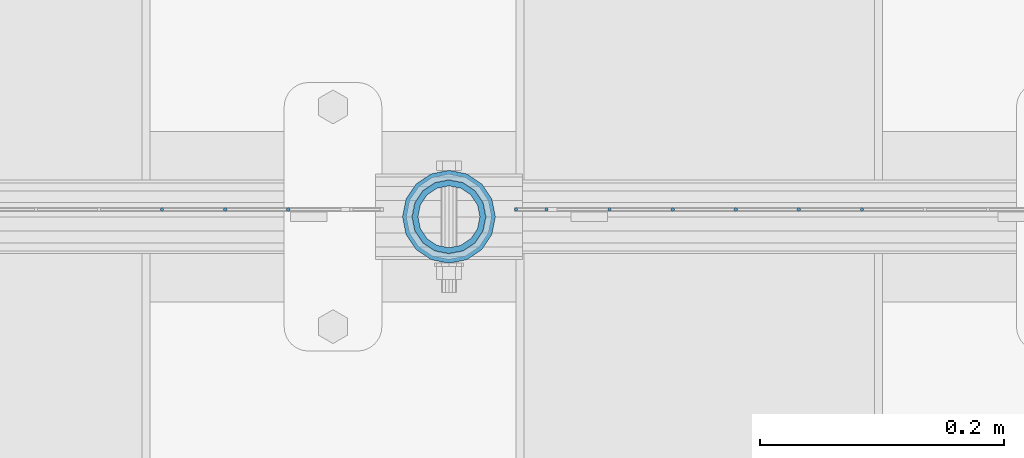
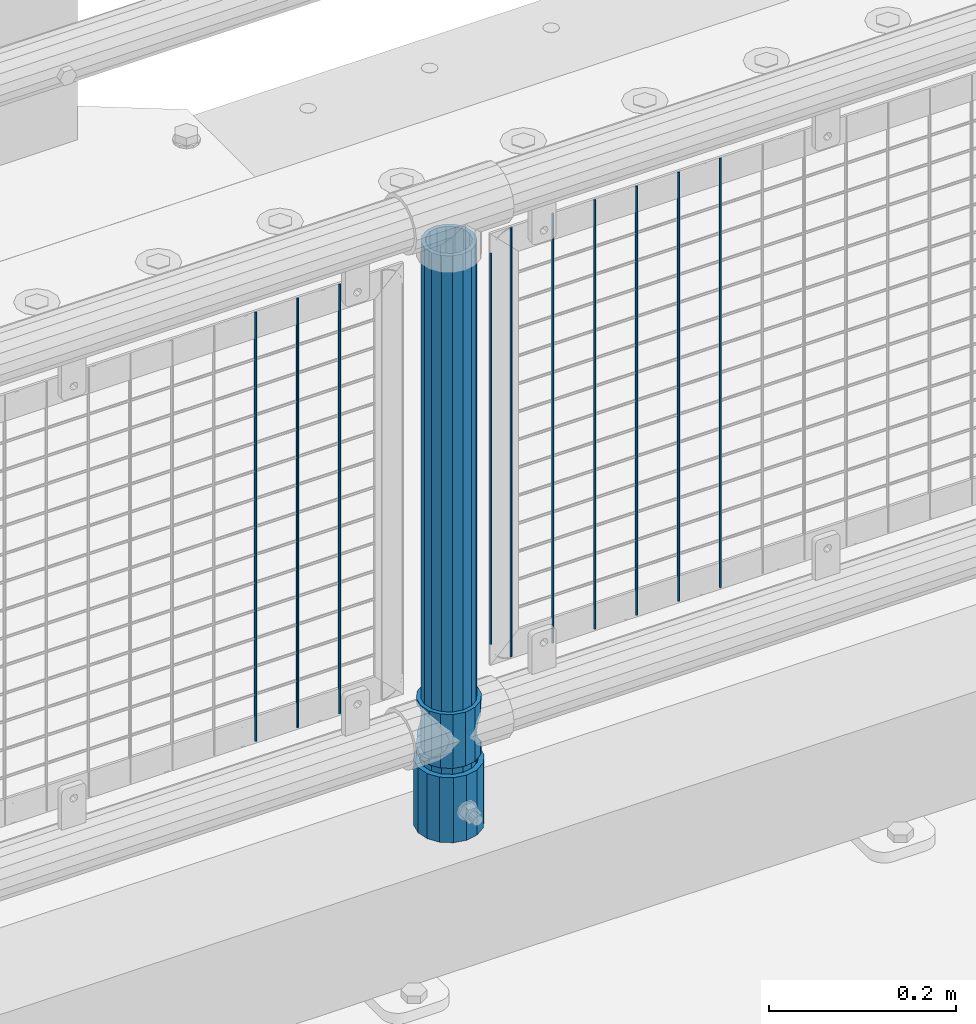
# One storey, part 74 of 219: 13 columns.
"""IFC2X3 building model written with IfcOpenShell, lengths in millimetres."""

from ifc_helpers import new_model, si_unit, frame, origin_with_axes, place, context, subcontext, project, spatial, faceted_brep, material, type_object, element, save


model = new_model("IFC2X3")

# Units and contexts
model_context = context("Model", 3, precision=1e-05, world=origin_with_axes())
body_context = subcontext(model_context, "Body", "Model", "MODEL_VIEW")
ifc_project = project(units=[si_unit("LENGTHUNIT", "METRE", prefix="MILLI"), si_unit("AREAUNIT", "SQUARE_METRE"), si_unit("VOLUMEUNIT", "CUBIC_METRE"), si_unit("MASSUNIT", "GRAM", prefix="KILO"), si_unit("TIMEUNIT", "SECOND"), si_unit("PLANEANGLEUNIT", "RADIAN"), si_unit("SOLIDANGLEUNIT", "STERADIAN"), si_unit("THERMODYNAMICTEMPERATUREUNIT", "DEGREE_CELSIUS"), si_unit("LUMINOUSINTENSITYUNIT", "LUMEN")], contexts=[model_context])

# Site, building, storey
site_placement = place(None, origin_with_axes())
site = spatial("IfcSite", under=ifc_project, at=site_placement, CompositionType="ELEMENT")
building_placement = place(site_placement, origin_with_axes())
building = spatial("IfcBuilding", under=site, at=building_placement, Name="Standard", CompositionType="ELEMENT")
storey_placement = place(building_placement, origin_with_axes())
storey = spatial("IfcBuildingStorey", under=building, at=storey_placement, Name="Undefined", CompositionType="ELEMENT", Elevation=0.0)

# Columns
ifc_material_1 = material(Name="Misc_Undefined")
column_type_1 = type_object("IfcColumnType", PredefinedType="NOTDEFINED")
column_1_placement = place(storey_placement, frame((5595.0, 31664.5, 263.02), z_axis=(-1.0, 0.0, 0.0), x_axis=(0.0, 0.0, 1.0)))
element("IfcColumn", 1, at=column_1_placement, inside=storey, type_object=column_type_1, material=ifc_material_1, context=body_context, shape_type="Brep", body=[
    faceted_brep([(56.6106908090114, 21.46069080901, -21.4606908090118), (56.6106908090114, 21.46069080901, -27.1226768591096), (61.9623795176703, 13.4513226476338, -32.4743655677721), (63.1897438117172, 11.614442172282, -32.8397438117172), (63.1897438117172, 11.614442172282, -28.0397438117179), (46.7644421722801, 28.0397438117179, -11.6144421722802), (46.7644421722801, 28.0397438117179, -20.0882031229849), (51.5310424080006, 24.8548033587067, -24.8548033587067), (35.1499999999996, 30.35, 0.0), (35.1499999999996, 30.3499999999985, -16.6306603983739), (23.5355578277192, 28.0397438117179, -11.6144421722802), (23.5355578277192, 28.0397438117179, -20.0882031229849), (13.6893091909879, 21.46069080901, -21.4606908090118), (13.6893091909879, 21.46069080901, -27.1226768591096), (18.7689575919987, 24.8548033587067, -24.8548033587067), (7.11025618828211, 11.614442172282, -28.0397438117179), (7.11025618828211, 11.614442172282, -32.8397438117172), (8.33762048232455, 13.4513226476338, -32.4743655677721), (4.79999999999961, 0.0, -30.3500000000004), (4.79999999999961, 0.0, -35.1499999999996), (7.11025618828211, -11.614442172282, -28.0397438117179), (7.11025618828211, -11.614442172282, -32.839743811719), (13.6893091909879, -21.46069080901, -21.4606908090118), (13.6893091909879, -21.46069080901, -27.1226768591077), (8.33762048232455, -13.4513226476338, -32.4743655677721), (23.5355578277191, -28.0397438117179, -11.6144421722802), (23.5355578277191, -28.0397438117179, -20.0882031229739), (18.7689575919921, -24.8548033587067, -24.8548033587067), (35.1499999999996, -30.35, 0.0), (35.1499999999996, -30.3499999999985, -16.6306603983649), (46.7644421722801, -28.0397438117179, -11.6144421722802), (46.7644421722801, -28.0397438117179, -20.0882031229739), (56.6106908090114, -21.46069080901, -21.4606908090118), (56.6106908090114, -21.46069080901, -27.1226768591077), (51.5310424080006, -24.8548033587067, -24.8548033587067), (63.1897438117172, -11.614442172282, -28.0397438117179), (63.1897438117172, -11.614442172282, -32.839743811719), (61.9623795176747, -13.4513226476338, -32.4743655677721), (65.4999999999997, 0.0, -30.3500000000004), (65.4999999999997, 0.0, -35.1499999999996), (0.0, -28.0397438117179, -11.6144421722802), (0.0, -30.3499999999985, 0.0), (0.0, -21.46069080901, -21.4606908090118), (0.0, -11.614442172282, -28.0397438117179), (0.0, 0.0, -30.3500000000004), (0.0, 11.614442172282, -28.0397438117179), (0.0, 21.46069080901, -21.4606908090118), (0.0, 28.0397438117179, -11.6144421722802), (0.0, 30.3499999999985, 0.0), (0.0, 28.0397438117179, 11.6144421722802), (23.5355578277192, 28.0397438117179, 11.6144421722806), (0.0, 21.46069080901, 21.4606908090118), (13.6893091909879, 21.46069080901, 21.4606908090118), (0.0, 11.614442172282, 28.0397438117179), (7.11025618828211, 11.614442172282, 28.0397438117175), (0.0, 0.0, 30.3500000000004), (4.79999999999961, 0.0, 30.3499999999999), (0.0, -11.614442172282, 28.0397438117179), (7.11025618828205, -11.614442172282, 28.0397438117175), (0.0, -21.46069080901, 21.4606908090118), (13.6893091909879, -21.46069080901, 21.4606908090118), (0.0, -28.0397438117179, 11.6144421722802), (23.5355578277191, -28.0397438117179, 11.6144421722806), (0.0, -32.4743655677703, 13.4513226476338), (0.0, -35.1500000000015, 0.0), (70.2999999999993, -35.1500000000015, 0.0), (70.2999999999993, -32.4743655677703, 13.4513226476338), (0.0, 13.4513226476338, -32.4743655677721), (0.0, 24.8548033587067, -24.8548033587067), (0.0, 0.0, -35.1500000000015), (0.0, -13.4513226476338, -32.4743655677721), (0.0, -24.8548033587067, -24.8548033587067), (0.0, -24.8548033587067, 24.8548033587067), (0.0, -13.4513226476338, 32.4743655677721), (0.0, 0.0, 35.1500000000015), (0.0, 13.4513226476338, 32.4743655677721), (0.0, 24.8548033587067, 24.8548033587067), (0.0, 32.4743655677703, 13.4513226476338), (0.0, 35.1500000000015, 0.0), (0.0, 32.4743655677703, -13.4513226476338), (0.0, -32.4743655677703, -13.4513226476338), (70.2999999999993, 32.4743655677703, 13.4513226476338), (70.2999999999993, 35.1500000000015, 0.0), (70.2999999999993, 32.4743655677703, -13.4513226476338), (70.2999999999993, 24.8548033587067, -24.8548033587067), (70.2999999999993, 13.4513226476338, -32.4743655677721), (70.2999999999993, 0.0, -35.1499999999996), (70.2999999999993, -13.4513226476338, -32.4743655677721), (70.2999999999993, -24.8548033587067, -24.8548033587067), (70.2999999999993, -32.4743655677703, -13.4513226476338), (70.2999999999993, 28.0397438117179, 11.6144421722802), (70.2999999999993, 21.46069080901, 21.4606908090118), (56.6106908090114, 21.46069080901, 21.4606908090118), (46.7644421722801, 28.0397438117179, 11.6144421722806), (70.2999999999993, 11.614442172282, 28.0397438117179), (63.1897438117172, 11.614442172282, 28.0397438117175), (70.2999999999993, 0.0, 30.3500000000004), (65.4999999999997, 0.0, 30.3499999999999), (70.2999999999993, -11.614442172282, 28.0397438117179), (63.1897438117172, -11.614442172282, 28.0397438117175), (70.2999999999993, -21.46069080901, 21.4606908090118), (56.6106908090114, -21.46069080901, 21.4606908090118), (70.2999999999993, -28.0397438117179, 11.6144421722802), (46.7644421722801, -28.0397438117179, 11.6144421722806), (70.2999999999993, -11.614442172282, -28.0397438117179), (70.2999999999993, 0.0, -30.3500000000004), (70.2999999999993, -21.46069080901, -21.4606908090118), (70.2999999999993, -28.0397438117179, -11.6144421722802), (70.2999999999993, -30.3499999999985, 0.0), (70.2999999999993, 24.8548033587067, 24.8548033587067), (70.2999999999993, 13.4513226476338, 32.4743655677721), (70.2999999999993, 0.0, 35.1499999999996), (70.2999999999993, -13.4513226476338, 32.4743655677721), (70.2999999999993, -24.8548033587067, 24.8548033587067), (70.2999999999993, 30.3499999999985, 0.0), (70.2999999999993, 28.0397438117179, -11.6144421722802), (70.2999999999993, 21.46069080901, -21.4606908090118), (70.2999999999993, 11.614442172282, -28.0397438117179), (61.9623795176742, 13.4513226476338, 32.4743655677717), (51.5310424080006, 24.8548033587067, 24.8548033587072), (56.6106908090114, 21.46069080901, 27.1226768591059), (65.4999999999997, 0.0, 35.1500000000001), (63.1897438117172, 11.614442172282, 32.8397438117177), (63.1897438117172, -11.614442172282, 32.8397438117177), (61.9623795176742, -13.4513226476338, 32.4743655677717), (56.6106908090114, -21.46069080901, 27.1226768591087), (51.5310424080006, -24.8548033587067, 24.8548033587072), (18.7689575919921, -24.8548033587067, 24.8548033587072), (46.7644421722801, -28.0397438117179, 20.0882031229862), (35.1499999999996, -30.3499999999985, 16.630660398373), (23.5355578277191, -28.0397438117179, 20.0882031229862), (8.33762048232506, -13.4513226476338, 32.4743655677717), (13.6893091909879, -21.46069080901, 27.1226768591087), (4.79999999999961, 0.0, 35.1500000000001), (7.11025618828205, -11.614442172282, 32.8397438117177), (7.11025618828211, 11.614442172282, 32.8397438117177), (8.33762048232069, 13.4513226476338, 32.4743655677717), (13.6893091909879, 21.46069080901, 27.1226768591059), (18.7689575919987, 24.8548033587067, 24.8548033587072), (23.5355578277192, 28.0397438117179, 20.0882031229794), (35.1499999999996, 30.3499999999985, 16.6306603983667), (46.7644421722801, 28.0397438117179, 20.0882031229794)], [[[0, 1, 2, 3, 4]], [[5, 6, 7, 1, 0]], [[8, 9, 6, 5]], [[10, 11, 9, 8]], [[12, 13, 14, 11, 10]], [[15, 16, 17, 13, 12]], [[18, 19, 16, 15]], [[20, 21, 19, 18]], [[22, 23, 24, 21, 20]], [[25, 26, 27, 23, 22]], [[28, 29, 26, 25]], [[30, 31, 29, 28]], [[32, 33, 34, 31, 30]], [[35, 36, 37, 33, 32]], [[38, 39, 36, 35]], [[4, 3, 39, 38]], [[40, 41, 28, 25]], [[42, 40, 25, 22]], [[43, 42, 22, 20]], [[44, 43, 20, 18]], [[45, 44, 18, 15]], [[46, 45, 15, 12]], [[47, 46, 12, 10]], [[48, 47, 10, 8]], [[49, 48, 8, 50]], [[51, 49, 50, 52]], [[53, 51, 52, 54]], [[55, 53, 54, 56]], [[57, 55, 56, 58]], [[59, 57, 58, 60]], [[61, 59, 60, 62]], [[41, 61, 62, 28]], [[63, 64, 65, 66]], [[17, 67, 68, 14, 13]], [[19, 69, 67, 17, 16]], [[70, 69, 19, 21, 24]], [[71, 70, 24, 23, 27]], [[63, 72, 73, 74, 75, 76, 77, 78, 79, 68, 67, 69, 70, 71, 80, 64], [40, 42, 43, 44, 45, 46, 47, 48, 49, 51, 53, 55, 57, 59, 61, 41]], [[78, 77, 81, 82]], [[79, 78, 82, 83]], [[14, 68, 79, 83, 84, 7, 6, 9, 11]], [[84, 85, 2, 1, 7]], [[85, 86, 39, 3, 2]], [[37, 87, 88, 34, 33]], [[39, 86, 87, 37, 36]], [[34, 88, 89, 80, 71, 27, 26, 29, 31]], [[64, 80, 89, 65]], [[90, 91, 92, 93]], [[91, 94, 95, 92]], [[94, 96, 97, 95]], [[96, 98, 99, 97]], [[98, 100, 101, 99]], [[100, 102, 103, 101]], [[104, 105, 38, 35]], [[106, 104, 35, 32]], [[107, 106, 32, 30]], [[108, 107, 30, 28]], [[102, 108, 28, 103]], [[88, 87, 86, 85, 84, 83, 82, 81, 109, 110, 111, 112, 113, 66, 65, 89], [100, 98, 96, 94, 91, 90, 114, 115, 116, 117, 105, 104, 106, 107, 108, 102]], [[118, 110, 109, 119, 120]], [[121, 111, 110, 118, 122]], [[112, 111, 121, 123, 124]], [[113, 112, 124, 125, 126]], [[127, 72, 63, 66, 113, 126, 128, 129, 130]], [[131, 73, 72, 127, 132]], [[133, 74, 73, 131, 134]], [[75, 74, 133, 135, 136]], [[76, 75, 136, 137, 138]], [[119, 109, 81, 77, 76, 138, 139, 140, 141]], [[92, 120, 119, 141, 93]], [[95, 122, 118, 120, 92]], [[97, 121, 122, 95]], [[99, 123, 121, 97]], [[101, 125, 124, 123, 99]], [[103, 128, 126, 125, 101]], [[28, 129, 128, 103]], [[62, 130, 129, 28]], [[60, 132, 127, 130, 62]], [[58, 134, 131, 132, 60]], [[56, 133, 134, 58]], [[54, 135, 133, 56]], [[52, 137, 136, 135, 54]], [[50, 139, 138, 137, 52]], [[8, 140, 139, 50]], [[93, 141, 140, 8]], [[114, 90, 93, 8]], [[115, 114, 8, 5]], [[116, 115, 5, 0]], [[117, 116, 0, 4]], [[105, 117, 4, 38]]]),
])
ifc_material_2 = material()
column_type_2 = type_object("IfcColumnType", PredefinedType="NOTDEFINED")
column_2_placement = place(storey_placement, frame((5595.0, 31664.5, 168.02), z_axis=(-1.0, 0.0, 0.0), x_axis=(0.0, 0.0, 1.0)))
element("IfcColumn", 2, at=column_2_placement, inside=storey, type_object=column_type_2, material=ifc_material_2, context=body_context, shape_type="Brep", body=[
    faceted_brep([(0.0, -25.3499999999985, 0.0), (0.0, -23.4203461491597, 9.70102501045585), (760.0, -23.4203461491597, 9.70102501045585), (760.0, -25.3499999999985, 0.0), (0.0, -17.9251569030785, 17.9251569030785), (760.0, -17.9251569030785, 17.9251569030785), (0.0, -9.70102501045403, 23.4203461491616), (760.0, -9.70102501045403, 23.4203461491616), (0.0, 0.0, 25.3500000000004), (760.0, 0.0, 25.3500000000004), (0.0, 9.70102501045403, 23.4203461491616), (760.0, 9.70102501045403, 23.4203461491616), (0.0, 17.9251569030785, 17.9251569030785), (760.0, 17.9251569030785, 17.9251569030785), (0.0, 23.4203461491597, 9.70102501045585), (760.0, 23.4203461491597, 9.70102501045585), (0.0, 25.3499999999985, 0.0), (760.0, 25.3499999999985, 0.0), (0.0, 23.4203461491597, -9.70102501045585), (760.0, 23.4203461491597, -9.70102501045585), (0.0, 17.9251569030785, -17.9251569030785), (760.0, 17.9251569030785, -17.9251569030785), (0.0, 9.70102501045403, -23.4203461491616), (760.0, 9.70102501045403, -23.4203461491616), (0.0, 0.0, -25.3500000000004), (760.0, 0.0, -25.3500000000004), (0.0, -9.70102501045403, -23.4203461491616), (760.0, -9.70102501045403, -23.4203461491616), (0.0, -17.9251569030785, -17.9251569030785), (760.0, -17.9251569030785, -17.9251569030785), (0.0, -23.4203461491597, -9.70102501045585), (760.0, -23.4203461491597, -9.70102501045585), (0.0, -30.1500000000015, 0.0), (0.0, -27.8549679052157, -11.5379054858076), (760.0, -27.8549679052157, -11.5379054858076), (760.0, -30.1500000000015, 0.0), (0.0, -21.3192694527752, -21.3192694527752), (760.0, -21.3192694527752, -21.3192694527752), (0.0, -11.5379054858058, -27.8549679052157), (760.0, -11.5379054858058, -27.8549679052157), (0.0, 0.0, -30.1499999999996), (760.0, 0.0, -30.1499999999996), (0.0, 11.5379054858058, -27.8549679052157), (760.0, 11.5379054858058, -27.8549679052157), (0.0, 21.3192694527752, -21.3192694527752), (760.0, 21.3192694527752, -21.3192694527752), (0.0, 27.8549679052157, -11.5379054858076), (760.0, 27.8549679052157, -11.5379054858076), (0.0, 30.1500000000015, 0.0), (760.0, 30.1500000000015, 0.0), (0.0, 27.8549679052157, 11.5379054858076), (760.0, 27.8549679052157, 11.5379054858076), (0.0, 21.3192694527752, 21.3192694527752), (760.0, 21.3192694527752, 21.3192694527752), (0.0, 11.5379054858058, 27.8549679052157), (760.0, 11.5379054858058, 27.8549679052157), (0.0, 0.0, 30.1499999999996), (760.0, 0.0, 30.1499999999996), (0.0, -11.5379054858058, 27.8549679052157), (760.0, -11.5379054858058, 27.8549679052157), (0.0, -21.3192694527752, 21.3192694527752), (760.0, -21.3192694527752, 21.3192694527752), (0.0, -27.8549679052157, 11.5379054858076), (760.0, -27.8549679052157, 11.5379054858076)], [[[0, 1, 2, 3]], [[1, 4, 5, 2]], [[4, 6, 7, 5]], [[6, 8, 9, 7]], [[8, 10, 11, 9]], [[10, 12, 13, 11]], [[12, 14, 15, 13]], [[14, 16, 17, 15]], [[16, 18, 19, 17]], [[18, 20, 21, 19]], [[20, 22, 23, 21]], [[22, 24, 25, 23]], [[24, 26, 27, 25]], [[26, 28, 29, 27]], [[28, 30, 31, 29]], [[30, 0, 3, 31]], [[32, 33, 34, 35]], [[33, 36, 37, 34]], [[36, 38, 39, 37]], [[38, 40, 41, 39]], [[40, 42, 43, 41]], [[42, 44, 45, 43]], [[44, 46, 47, 45]], [[46, 48, 49, 47]], [[48, 50, 51, 49]], [[50, 52, 53, 51]], [[52, 54, 55, 53]], [[54, 56, 57, 55]], [[56, 58, 59, 57]], [[58, 60, 61, 59]], [[60, 62, 63, 61]], [[62, 32, 35, 63]], [[37, 39, 41, 43, 45, 47, 49, 51, 53, 55, 57, 59, 61, 63, 35, 34], [5, 7, 9, 11, 13, 15, 17, 19, 21, 23, 25, 27, 29, 31, 3, 2]], [[62, 60, 58, 56, 54, 52, 50, 48, 46, 44, 42, 40, 38, 36, 33, 32], [30, 28, 26, 24, 22, 20, 18, 16, 14, 12, 10, 8, 6, 4, 1, 0]]]),
])
column_type_3 = type_object("IfcColumnType", PredefinedType="NOTDEFINED")
column_3_placement = place(storey_placement, frame((5595.0, 31664.5, 168.02), z_axis=(0.0, 1.0, 0.0), x_axis=(0.0, 0.0, 1.0)))
element("IfcColumn", 3, at=column_3_placement, inside=storey, type_object=column_type_3, material=ifc_material_2, context=body_context, shape_type="Brep", body=[
    faceted_brep([(0.0, -31.75, 0.0), (0.0, -29.3331751572332, 12.1501989775934), (85.0, -29.3331751572332, 12.1501989775934), (85.0, -31.75, 0.0), (0.0, -22.4506403026735, 22.4506403026717), (85.0, -22.4506403026735, 22.4506403026717), (0.0, -12.1501989775916, 29.3331751572332), (85.0, -12.1501989775916, 29.3331751572332), (0.0, 0.0, 31.75), (85.0, 0.0, 31.75), (0.0, 12.1501989775916, 29.3331751572332), (85.0, 12.1501989775916, 29.3331751572332), (0.0, 22.4506403026735, 22.4506403026717), (85.0, 22.4506403026735, 22.4506403026717), (0.0, 29.3331751572332, 12.1501989775934), (85.0, 29.3331751572332, 12.1501989775934), (0.0, 31.75, 0.0), (85.0, 31.75, 0.0), (0.0, 29.3331751572332, -12.1501989775934), (85.0, 29.3331751572332, -12.1501989775934), (0.0, 22.4506403026735, -22.4506403026717), (85.0, 22.4506403026735, -22.4506403026717), (0.0, 12.1501989775916, -29.3331751572332), (85.0, 12.1501989775916, -29.3331751572332), (0.0, 0.0, -31.75), (85.0, 0.0, -31.75), (0.0, -12.1501989775916, -29.3331751572332), (85.0, -12.1501989775916, -29.3331751572332), (0.0, -22.4506403026735, -22.4506403026717), (85.0, -22.4506403026735, -22.4506403026717), (0.0, -29.3331751572332, -12.1501989775934), (85.0, -29.3331751572332, -12.1501989775934), (0.0, -38.0499999999993, 0.0), (0.0, -35.1536162120537, -14.5611046014928), (85.0, -35.1536162120537, -14.5611046014928), (85.0, -38.0499999999993, 0.0), (0.0, -26.9054130241475, -26.9054130241493), (85.0, -26.9054130241475, -26.9054130241493), (0.0, -14.561104601491, -35.1536162120537), (85.0, -14.561104601491, -35.1536162120537), (0.0, 0.0, -38.0499999999993), (85.0, 0.0, -38.0499999999993), (0.0, 14.561104601491, -35.1536162120537), (85.0, 14.561104601491, -35.1536162120537), (0.0, 26.9054130241475, -26.9054130241493), (85.0, 26.9054130241475, -26.9054130241493), (0.0, 35.1536162120537, -14.5611046014928), (85.0, 35.1536162120537, -14.5611046014928), (0.0, 38.0499999999993, 0.0), (85.0, 38.0499999999993, 0.0), (0.0, 35.1536162120537, 14.5611046014928), (85.0, 35.1536162120537, 14.5611046014928), (0.0, 26.9054130241475, 26.9054130241493), (85.0, 26.9054130241475, 26.9054130241493), (0.0, 14.561104601491, 35.1536162120537), (85.0, 14.561104601491, 35.1536162120537), (0.0, 0.0, 38.0499999999993), (85.0, 0.0, 38.0499999999993), (0.0, -14.561104601491, 35.1536162120537), (85.0, -14.561104601491, 35.1536162120537), (0.0, -26.9054130241475, 26.9054130241493), (85.0, -26.9054130241475, 26.9054130241493), (0.0, -35.1536162120537, 14.5611046014928), (85.0, -35.1536162120537, 14.5611046014928)], [[[0, 1, 2, 3]], [[1, 4, 5, 2]], [[4, 6, 7, 5]], [[6, 8, 9, 7]], [[8, 10, 11, 9]], [[10, 12, 13, 11]], [[12, 14, 15, 13]], [[14, 16, 17, 15]], [[16, 18, 19, 17]], [[18, 20, 21, 19]], [[20, 22, 23, 21]], [[22, 24, 25, 23]], [[24, 26, 27, 25]], [[26, 28, 29, 27]], [[28, 30, 31, 29]], [[30, 0, 3, 31]], [[32, 33, 34, 35]], [[33, 36, 37, 34]], [[36, 38, 39, 37]], [[38, 40, 41, 39]], [[40, 42, 43, 41]], [[42, 44, 45, 43]], [[44, 46, 47, 45]], [[46, 48, 49, 47]], [[48, 50, 51, 49]], [[50, 52, 53, 51]], [[52, 54, 55, 53]], [[54, 56, 57, 55]], [[56, 58, 59, 57]], [[58, 60, 61, 59]], [[60, 62, 63, 61]], [[62, 32, 35, 63]], [[37, 39, 41, 43, 45, 47, 49, 51, 53, 55, 57, 59, 61, 63, 35, 34], [5, 7, 9, 11, 13, 15, 17, 19, 21, 23, 25, 27, 29, 31, 3, 2]], [[62, 60, 58, 56, 54, 52, 50, 48, 46, 44, 42, 40, 38, 36, 33, 32], [30, 28, 26, 24, 22, 20, 18, 16, 14, 12, 10, 8, 6, 4, 1, 0]]]),
])
column_type_4 = type_object("IfcColumnType", Name="D3", PredefinedType="NOTDEFINED")
for number, where, z_axis, x_axis in (
    (4, (5933.275, 31670.5, 353.02), (-1.0, 0.0, 0.0), (0.0, 0.0, 1.0)),
    (5, (5881.62, 31670.5, 353.02), (-1.0, 0.0, 0.0), (0.0, 0.0, 1.0)),
    (6, (5829.965, 31670.5, 353.02), (-1.0, 0.0, 0.0), (0.0, 0.0, 1.0)),
    (7, (5778.31, 31670.5, 353.02), (-1.0, 0.0, 0.0), (0.0, 0.0, 1.0)),
    (8, (5726.655, 31670.5, 353.02), (-1.0, 0.0, 0.0), (0.0, 0.0, 1.0)),
):
    element("IfcColumn", number, at=place(storey_placement, frame(where, z_axis=z_axis, x_axis=x_axis)), inside=storey, type_object=column_type_4, material=ifc_material_1, ObjectType="D3", context=body_context, shape_type="Brep", body=[
        faceted_brep([(0.0, -1.5, -5.6843418860808e-14), (0.0, -0.75, -1.29903810567669), (560.0, -0.75, -1.29903810567703), (560.0, -1.5, 0.0), (0.0, 0.75, -1.29903810567669), (560.0, 0.75, -1.29903810567703), (0.0, 1.5, -5.6843418860808e-14), (560.0, 1.5, 0.0), (0.0, 0.75, 1.29903810567669), (560.0, 0.75, 1.29903810567703), (0.0, -0.75, 1.29903810567669), (560.0, -0.75, 1.29903810567703)], [[[0, 1, 2, 3]], [[1, 4, 5, 2]], [[4, 6, 7, 5]], [[6, 8, 9, 7]], [[8, 10, 11, 9]], [[10, 0, 3, 11]], [[5, 7, 9, 11, 3, 2]], [[10, 8, 6, 4, 1, 0]]]),
    ])
column_4_placement = place(storey_placement, frame((5650.0, 31670.5, 378.02), z_axis=(-1.0, 0.0, 0.0), x_axis=(0.0, 0.0, 1.0)))
element("IfcColumn", 9, at=column_4_placement, inside=storey, type_object=column_type_4, material=ifc_material_1, ObjectType="D3", context=body_context, shape_type="Brep", body=[
    faceted_brep([(0.0, -1.5, -5.6843418860808e-14), (0.0, -0.75, -1.29903810567669), (510.0, -0.75, -1.29903810567703), (510.0, -1.5, 0.0), (0.0, 0.75, -1.29903810567669), (510.0, 0.75, -1.29903810567703), (0.0, 1.5, -5.6843418860808e-14), (510.0, 1.5, 0.0), (0.0, 0.75, 1.29903810567669), (510.0, 0.75, 1.29903810567703), (0.0, -0.75, 1.29903810567669), (510.0, -0.75, 1.29903810567703)], [[[0, 1, 2, 3]], [[1, 4, 5, 2]], [[4, 6, 7, 5]], [[6, 8, 9, 7]], [[8, 10, 11, 9]], [[10, 0, 3, 11]], [[5, 7, 9, 11, 3, 2]], [[10, 8, 6, 4, 1, 0]]]),
])
for number, where, z_axis, x_axis in (
    (10, (5675.0, 31670.5, 353.02), (-1.0, 0.0, 0.0), (0.0, 0.0, 1.0)),
    (11, (5463.34, 31670.5, 353.02), (-1.0, 0.0, 0.0), (0.0, 0.0, 1.0)),
    (12, (5411.685, 31670.5, 353.02), (-1.0, 0.0, 0.0), (0.0, 0.0, 1.0)),
    (13, (5360.03, 31670.5, 353.02), (-1.0, 0.0, 0.0), (0.0, 0.0, 1.0)),
):
    element("IfcColumn", number, at=place(storey_placement, frame(where, z_axis=z_axis, x_axis=x_axis)), inside=storey, type_object=column_type_4, material=ifc_material_1, ObjectType="D3", context=body_context, shape_type="Brep", body=[
        faceted_brep([(0.0, -1.5, -5.6843418860808e-14), (0.0, -0.75, -1.29903810567669), (560.0, -0.75, -1.29903810567703), (560.0, -1.5, 0.0), (0.0, 0.75, -1.29903810567669), (560.0, 0.75, -1.29903810567703), (0.0, 1.5, -5.6843418860808e-14), (560.0, 1.5, 0.0), (0.0, 0.75, 1.29903810567669), (560.0, 0.75, 1.29903810567703), (0.0, -0.75, 1.29903810567669), (560.0, -0.75, 1.29903810567703)], [[[0, 1, 2, 3]], [[1, 4, 5, 2]], [[4, 6, 7, 5]], [[6, 8, 9, 7]], [[8, 10, 11, 9]], [[10, 0, 3, 11]], [[5, 7, 9, 11, 3, 2]], [[10, 8, 6, 4, 1, 0]]]),
    ])

save(model, "model.ifc")
